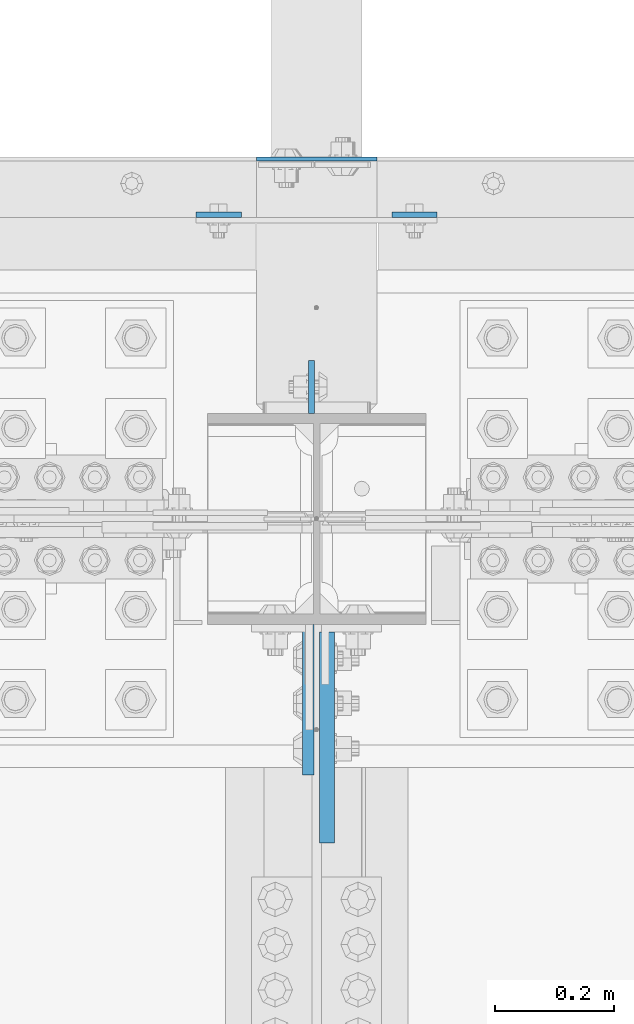
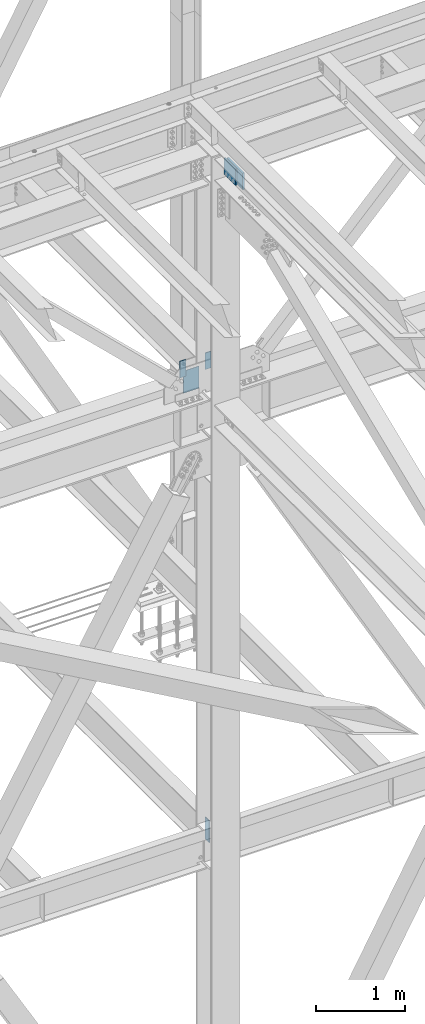
# One storey, part 1588 of 3843: 6 columns, 4 elements without a shape of their own.
"""IFC2X3 building model written with IfcOpenShell, lengths in millimetres."""

from ifc_helpers import new_model, si_unit, frame, origin_with_axes, place, context, subcontext, project, spatial, faceted_brep, material, type_object, element, aggregate, save


model = new_model("IFC2X3")

# Units and contexts
model_context = context("Model", 3, precision=1e-05, world=origin_with_axes())
body_context = subcontext(model_context, "Body", "Model", "MODEL_VIEW")
ifc_project = project(units=[si_unit("LENGTHUNIT", "METRE", prefix="MILLI"), si_unit("AREAUNIT", "SQUARE_METRE"), si_unit("VOLUMEUNIT", "CUBIC_METRE"), si_unit("MASSUNIT", "GRAM", prefix="KILO"), si_unit("TIMEUNIT", "SECOND"), si_unit("PLANEANGLEUNIT", "RADIAN"), si_unit("SOLIDANGLEUNIT", "STERADIAN"), si_unit("THERMODYNAMICTEMPERATUREUNIT", "DEGREE_CELSIUS"), si_unit("LUMINOUSINTENSITYUNIT", "LUMEN")], contexts=[model_context])

# Site, building, storey
site_placement = place(None, origin_with_axes())
site = spatial("IfcSite", under=ifc_project, at=site_placement, CompositionType="ELEMENT")
building_placement = place(site_placement, origin_with_axes())
building = spatial("IfcBuilding", under=site, at=building_placement, Name="Undefined", CompositionType="ELEMENT")
storey_placement = place(building_placement, origin_with_axes())
storey = spatial("IfcBuildingStorey", under=building, at=storey_placement, Name="Undefined", CompositionType="ELEMENT", Elevation=0.0)

# Assembly, column
assembly_1_placement = place(storey_placement, origin_with_axes())
assembly_1 = element("IfcElementAssembly", 1, at=assembly_1_placement, inside=storey, Name="COLUMN", AssemblyPlace="NOTDEFINED", PredefinedType="RIGID_FRAME")
ifc_material = material(Name="STEEL/A572-50")
column_type_1 = type_object("IfcColumnType", PredefinedType="NOTDEFINED")
column_1_placement = place(assembly_1_placement, frame((55930.8, 92821.125, 42062.4), z_axis=(-1.0, 0.0, 0.0), x_axis=(0.0, 0.0, 1.0)))
column_1 = element("IfcColumn", 2, at=column_1_placement, type_object=column_type_1, material=ifc_material, Name="PLATE", context=body_context, shape_type="Brep", body=[
    faceted_brep([(0.0, 3.17499999999927, -101.600000000006), (0.0, 3.17499999999927, 101.600000000006), (304.800000000003, 3.17499999999927, 101.600000000006), (304.800000000003, 3.17499999999927, -101.600000000006), (0.0, -3.17499999999927, 101.600000000006), (304.800000000003, -3.17499999999927, 101.600000000006), (0.0, -3.17499999999927, -101.600000000006), (304.800000000003, -3.17499999999927, -101.600000000006)], [[[0, 1, 2, 3]], [[1, 4, 5, 2]], [[4, 6, 7, 5]], [[6, 0, 3, 7]], [[5, 7, 3, 2]], [[6, 4, 1, 0]]]),
])

assembly_2_placement = place(storey_placement, origin_with_axes())
assembly_2 = element("IfcElementAssembly", 3, at=assembly_2_placement, inside=storey, Name="GIRT", AssemblyPlace="NOTDEFINED", PredefinedType="RIGID_FRAME")
column_type_2 = type_object("IfcColumnType", PredefinedType="NOTDEFINED")
column_2_placement = place(assembly_2_placement, frame((55765.7, 92727.4625, 42367.2), z_axis=(-1.0, 0.0, 0.0), x_axis=(0.0, 0.0, 1.0)))
column_2 = element("IfcColumn", 4, at=column_2_placement, type_object=column_type_2, material=ifc_material, Name="PLATE", context=body_context, shape_type="Brep", body=[
    faceted_brep([(0.0, 4.76250000000073, -38.0999999999985), (0.0, 4.76250000000073, 38.0999999999985), (228.599999999999, 4.76249999999709, 38.1000000000058), (228.599999999999, 4.76249999999709, -38.1000000000058), (0.0, -4.76250000000073, 38.0999999999985), (228.599999999999, -4.76249999999709, 38.1000000000058), (0.0, -4.76250000000073, -38.0999999999985), (228.599999999999, -4.76249999999709, -38.1000000000058)], [[[0, 1, 2, 3]], [[1, 4, 5, 2]], [[4, 6, 7, 5]], [[6, 0, 3, 7]], [[5, 7, 3, 2]], [[6, 4, 1, 0]]]),
])
aggregate(assembly_2, [column_2])

assembly_3_placement = place(storey_placement, origin_with_axes())
assembly_3 = element("IfcElementAssembly", 5, at=assembly_3_placement, inside=storey, Name="GIRT", AssemblyPlace="NOTDEFINED", PredefinedType="RIGID_FRAME")
column_3_placement = place(assembly_3_placement, frame((56095.9, 92727.4625, 42367.2), z_axis=(-1.0, 0.0, 0.0), x_axis=(0.0, 0.0, 1.0)))
column_3 = element("IfcColumn", 6, at=column_3_placement, type_object=column_type_2, material=ifc_material, Name="PLATE", context=body_context, shape_type="Brep", body=[
    faceted_brep([(0.0, 4.76250000000073, -38.0999999999985), (0.0, 4.76250000000073, 38.0999999999985), (228.599999999999, 4.76249999999709, 38.1000000000058), (228.599999999999, 4.76249999999709, -38.1000000000058), (0.0, -4.76250000000073, 38.0999999999985), (228.599999999999, -4.76249999999709, 38.1000000000058), (0.0, -4.76250000000073, -38.0999999999985), (228.599999999999, -4.76249999999709, -38.1000000000058)], [[[0, 1, 2, 3]], [[1, 4, 5, 2]], [[4, 6, 7, 5]], [[6, 0, 3, 7]], [[5, 7, 3, 2]], [[6, 4, 1, 0]]]),
])
aggregate(assembly_3, [column_3])

# Column
column_type_3 = type_object("IfcColumnType", PredefinedType="NOTDEFINED")
column_4_placement = place(assembly_1_placement, frame((55922.06875, 92436.95, 36093.4), z_axis=(0.0, -1.0, 0.0), x_axis=(0.0, 0.0, 1.0)))
column_4 = element("IfcColumn", 7, at=column_4_placement, type_object=column_type_3, material=ifc_material, Name="PLATE", context=body_context, shape_type="Brep", body=[
    faceted_brep([(0.0, 4.76249999999709, -44.4500000000007), (0.0, 4.76249999999709, 44.4500000000007), (304.799999999996, 4.76249999999709, 44.4500000000007), (304.799999999996, 4.76249999999709, -44.4500000000007), (0.0, -4.76249999999709, 44.4500000000007), (304.799999999996, -4.76249999999709, 44.4500000000007), (0.0, -4.76249999999709, -44.4500000000007), (304.799999999996, -4.76249999999709, -44.4500000000007)], [[[0, 1, 2, 3]], [[1, 4, 5, 2]], [[4, 6, 7, 5]], [[6, 0, 3, 7]], [[5, 7, 3, 2]], [[6, 4, 1, 0]]]),
])

column_type_4 = type_object("IfcColumnType", PredefinedType="NOTDEFINED")
column_5_placement = place(assembly_1_placement, frame((55916.512571804, 91909.9, 45526.0034830344), z_axis=(0.0, 1.0, 0.0), x_axis=(0.0, 0.0, 1.0)))
column_5 = element("IfcColumn", 8, at=column_5_placement, type_object=column_type_4, material=ifc_material, Name="PLATE", context=body_context, shape_type="Brep", body=[
    faceted_brep([(0.0, 9.52499999999418, -127.0), (0.0, 9.52499999999418, 127.0), (228.599999999999, 9.52499999999418, 127.0), (228.599999999999, 9.52499999999418, -127.0), (0.0, -9.52499999999418, 127.0), (228.599999999999, -9.52499999999418, 127.0), (0.0, -9.52499999999418, -127.0), (228.599999999999, -9.52499999999418, -127.0)], [[[0, 1, 2, 3]], [[1, 4, 5, 2]], [[4, 6, 7, 5]], [[6, 0, 3, 7]], [[5, 7, 3, 2]], [[6, 4, 1, 0]]]),
])

aggregate(assembly_1, [column_1, column_5, column_4])

# Assembly, column
assembly_4_placement = place(storey_placement, origin_with_axes())
assembly_4 = element("IfcElementAssembly", 9, at=assembly_4_placement, inside=storey, Name="BEAM", AssemblyPlace="NOTDEFINED", PredefinedType="RIGID_FRAME")
column_type_5 = type_object("IfcColumnType", PredefinedType="NOTDEFINED")
column_6_placement = place(assembly_4_placement, frame((55948.2624999997, 91846.4, 45526.0034830344), z_axis=(0.0, 1.0, 0.0), x_axis=(0.0, 0.0, 1.0)))
column_6 = element("IfcColumn", 10, at=column_6_placement, type_object=column_type_5, material=ifc_material, Name="PLATE", context=body_context, shape_type="Brep", body=[
    faceted_brep([(-1.45519152283669e-11, 12.7000000000025, -177.800000000003), (-1.45519152283669e-11, 12.7000000000025, 177.800000000003), (228.600000000013, 12.6999999999971, 177.799999999999), (228.600000000013, 12.6999999999971, -177.799999999999), (4.36557456851006e-11, -12.7000000000171, 177.800000000003), (228.600000000013, -12.6999999999971, 177.799999999999), (4.36557456851006e-11, -12.7000000000171, -177.800000000003), (228.600000000013, -12.6999999999971, -177.799999999999)], [[[0, 1, 2, 3]], [[1, 4, 5, 2]], [[4, 6, 7, 5]], [[6, 0, 3, 7]], [[5, 7, 3, 2]], [[6, 4, 1, 0]]]),
])
aggregate(assembly_4, [column_6])

save(model, "model.ifc")
